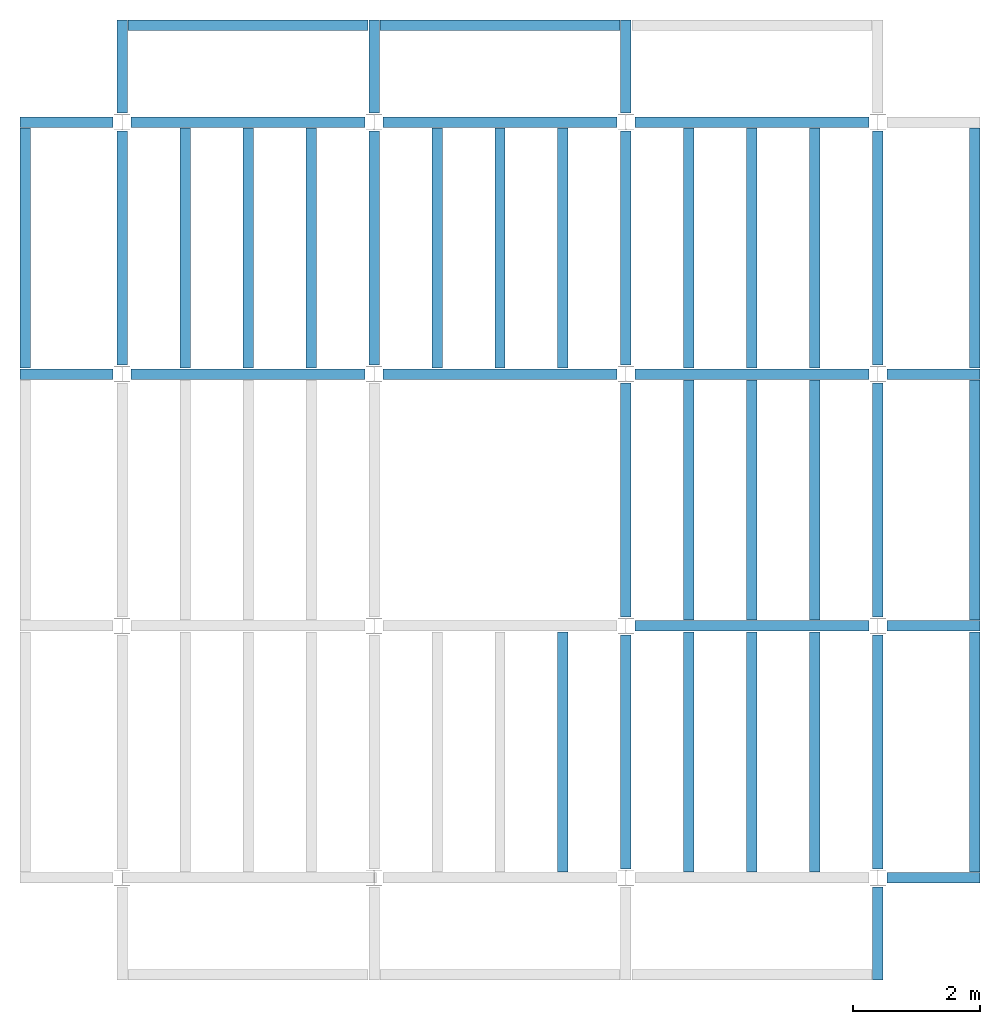
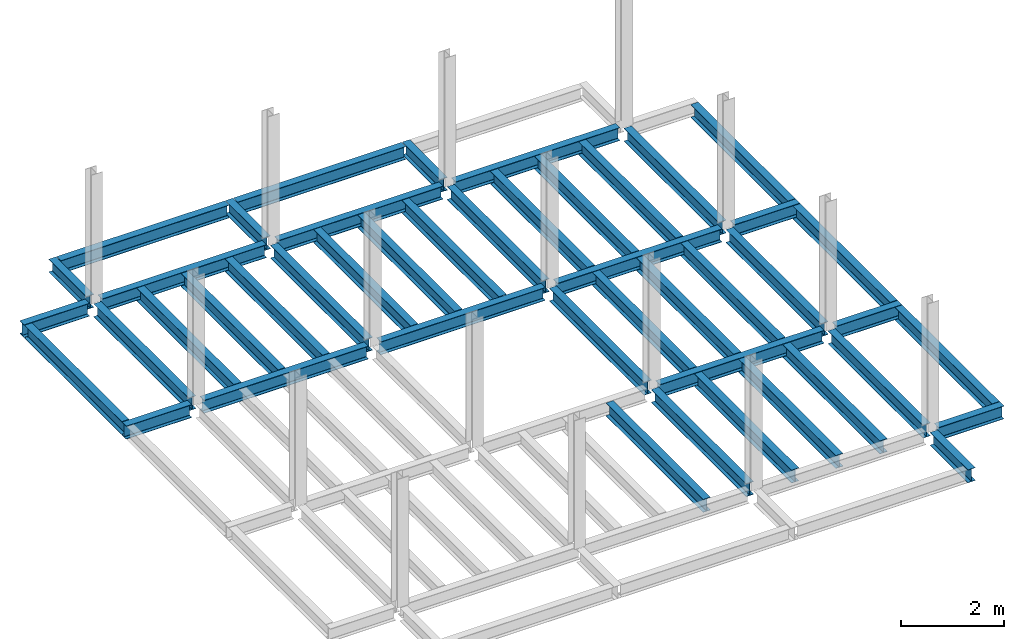
# One storey, part 2 of 3: 46 beams, 6 elements without a shape of their own.
"""IFC4 building model written with IfcOpenShell, lengths in feet."""

from ifc_helpers import new_model, entity, si_unit, converted_unit, derived_unit, direction, frame, origin, place, context, subcontext, project, spatial, line, arc, indexed_curve, outline, extrude, source, transform, mapped, material, type_object, type_shapes, element, aggregate, save


model = new_model("IFC4")

# Units and contexts
model_context = context("Model", 3, precision=0.0001, world=origin(), true_north=direction((6.123233995736766e-17, 1.0)))
plan_context = context("Plan", 3, precision=0.0001, world=origin(), true_north=direction((6.123233995736766e-17, 1.0)))
body_context = subcontext(model_context, "Body", "Model", "MODEL_VIEW")
ifc_project = project(units=[converted_unit("LENGTHUNIT", "FOOT", entity("IfcLengthMeasure", 0.3048), si_unit("LENGTHUNIT", "METRE"), dimensions=[1, 0, 0, 0, 0, 0, 0]), converted_unit("AREAUNIT", "SQUARE FOOT", entity("IfcAreaMeasure", 0.09290304), si_unit("AREAUNIT", "SQUARE_METRE"), dimensions=[2, 0, 0, 0, 0, 0, 0]), converted_unit("PLANEANGLEUNIT", "DEGREE", entity("IfcPlaneAngleMeasure", 0.017453292519943278), si_unit("PLANEANGLEUNIT", "RADIAN"), dimensions=[0, 0, 0, 0, 0, 0, 0]), converted_unit("VOLUMEUNIT", "CUBIC FOOT", entity("IfcVolumeMeasure", 0.028316846592000004), si_unit("VOLUMEUNIT", "CUBIC_METRE"), dimensions=[3, 0, 0, 0, 0, 0, 0]), si_unit("PRESSUREUNIT", "PASCAL"), derived_unit("MASSDENSITYUNIT", [(si_unit("MASSUNIT", "GRAM", prefix="KILO"), 1), (si_unit("LENGTHUNIT", "METRE"), -3)]), derived_unit("VAPORPERMEABILITYUNIT", [(si_unit("LENGTHUNIT", "METRE"), -1), (si_unit("TIMEUNIT", "SECOND"), 1)]), derived_unit("USERDEFINED", [(si_unit("MASSUNIT", "GRAM", prefix="KILO"), 1), (si_unit("LENGTHUNIT", "METRE"), 3), (si_unit("TIMEUNIT", "SECOND"), -3), (si_unit("ELECTRICCURRENTUNIT", "AMPERE"), -2)]), derived_unit("MODULUSOFELASTICITYUNIT", [(si_unit("MASSUNIT", "GRAM", prefix="KILO"), 1), (si_unit("LENGTHUNIT", "METRE"), -1), (si_unit("TIMEUNIT", "SECOND"), -2)]), derived_unit("THERMALEXPANSIONCOEFFICIENTUNIT", [(si_unit("THERMODYNAMICTEMPERATUREUNIT", "KELVIN"), -1)]), derived_unit("SPECIFICHEATCAPACITYUNIT", [(si_unit("TIMEUNIT", "SECOND"), -2), (si_unit("THERMODYNAMICTEMPERATUREUNIT", "KELVIN"), -1), (si_unit("LENGTHUNIT", "METRE"), 2)]), derived_unit("THERMALCONDUCTANCEUNIT", [(si_unit("MASSUNIT", "GRAM", prefix="KILO"), 1), (si_unit("TIMEUNIT", "SECOND"), -3), (si_unit("THERMODYNAMICTEMPERATUREUNIT", "KELVIN"), -1), (si_unit("LENGTHUNIT", "METRE"), 1)])], contexts=[model_context, plan_context])

# Site, building, storey
site_placement = place(None, origin())
site = spatial("IfcSite", under=ifc_project, at=site_placement, CompositionType="ELEMENT")
building_placement = place(site_placement, origin())
building = spatial("IfcBuilding", under=site, at=building_placement, CompositionType="ELEMENT")
storey_placement = place(building_placement, frame((0.0, 0.0, 59.875)))
storey = spatial("IfcBuildingStorey", under=building, at=storey_placement, Name="STR 07", CompositionType="ELEMENT", Elevation=59.875)

# Beams
ifc_material = material(Name="Steel ASTM A992", Category="Metal")
beam_type_1 = type_object("IfcBeamType", Name="W12X26", PredefinedType="JOIST", material=ifc_material)
shared_shape_1 = source(origin(), body_context, "Body", "SweptSolid", [
    extrude(outline(indexed_curve([(-0.27041666666666714, -0.47666666666666574), (-0.27041666666666714, -0.5083333333333351), (0.2704166666666669, -0.5083333333333351), (0.2704166666666669, -0.47666666666666574), (0.03458333333333309, -0.47666666666666574), (0.016905663803669493, -0.46934433619632937), (0.009583333333333202, -0.4516666666666659), (0.0095833333333332, 0.45166666666666705), (0.01690566380366948, 0.4693443361963307), (0.03458333333333325, 0.4766666666666671), (0.2704166666666669, 0.4766666666666671), (0.2704166666666669, 0.5083333333333312), (-0.2704166666666655, 0.5083333333333312), (-0.2704166666666655, 0.4766666666666671), (-0.034583333333333514, 0.47666666666666707), (-0.016905663803669865, 0.46934433619633054), (-0.009583333333333737, 0.45166666666666694), (-0.009583333333333735, -0.4516666666666658), (-0.01690566380367013, -0.4693443361963295), (-0.03458333333333368, -0.47666666666666574)], segments=[line(1, 2, 3, 4, 5), arc(5, 6, 7), line(7, 8), arc(8, 9, 10), line(10, 11, 12, 13, 14, 15), arc(15, 16, 17), line(17, 18), arc(18, 19, 20), line(20, 1)], self_intersect=False)), frame((-6.103346456692914, 0.0, 0.0), z_axis=(-1.0, 0.0, 0.0), x_axis=(0.0, -1.0, 0.0)), (0.0, 0.0, -1.0), 12.083333333333323),
])
type_shapes(beam_type_1, [shared_shape_1])
for number, where, name in (
    (1, (6.561679790026307, 39.0, -0.5083333333333329), "W12X26"),
    (2, (6.561679790026288, 26.0, -0.5083333333333329), "W12X26"),
):
    element("IfcBeam", number, at=place(storey_placement, frame(where)), inside=storey, type_object=beam_type_1, material=ifc_material, Name=name, ObjectType="W Shapes:W12X26", PredefinedType="JOIST", context=body_context, shape_type="MappedRepresentation", body=[
        mapped(shared_shape_1, transform((0.0, 0.0, 0.0), scale=1.0)),
    ])
for number, where, z_axis, x_axis, name in (
    (3, (39.0, 6.56167979002612, -0.5083333333333329), (0.0, 0.0, 1.0), (0.0, 1.0, 0.0), "W12X26"),
    (4, (26.0, 6.561679790026162, -0.5083333333333329), (0.0, 0.0, 1.0), (0.0, 1.0, 0.0), "W12X26"),
):
    element("IfcBeam", number, at=place(storey_placement, frame(where, z_axis=z_axis, x_axis=x_axis)), inside=storey, type_object=beam_type_1, material=ifc_material, Name=name, ObjectType="W Shapes:W12X26", PredefinedType="JOIST", context=body_context, shape_type="MappedRepresentation", body=[
        mapped(shared_shape_1, transform((0.0, 0.0, 0.0), scale=1.0)),
    ])
beam_type_2 = type_object("IfcBeamType", Name="W12X26", PredefinedType="JOIST", material=ifc_material)
shared_shape_2 = source(origin(), body_context, "Body", "SweptSolid", [
    extrude(outline(indexed_curve([(-0.27041666666666714, -0.47666666666666574), (-0.27041666666666714, -0.5083333333333351), (0.2704166666666669, -0.5083333333333351), (0.2704166666666669, -0.47666666666666574), (0.03458333333333309, -0.47666666666666574), (0.016905663803669493, -0.46934433619632937), (0.009583333333333202, -0.4516666666666659), (0.0095833333333332, 0.45166666666666705), (0.01690566380366948, 0.4693443361963307), (0.03458333333333325, 0.4766666666666671), (0.2704166666666669, 0.4766666666666671), (0.2704166666666669, 0.5083333333333312), (-0.2704166666666655, 0.5083333333333312), (-0.2704166666666655, 0.4766666666666671), (-0.034583333333333514, 0.47666666666666707), (-0.016905663803669865, 0.46934433619633054), (-0.009583333333333737, 0.45166666666666694), (-0.009583333333333735, -0.4516666666666658), (-0.01690566380367013, -0.4693443361963295), (-0.03458333333333368, -0.47666666666666574)], segments=[line(1, 2, 3, 4, 5), arc(5, 6, 7), line(7, 8), arc(8, 9, 10), line(10, 11, 12, 13, 14, 15), arc(15, 16, 17), line(17, 18), arc(18, 19, 20), line(20, 1)], self_intersect=False)), frame((-6.226706036745409, 0.0, 0.0), z_axis=(-1.0, 0.0, 0.0), x_axis=(0.0, -1.0, 0.0)), (0.0, 0.0, -1.0), 12.08333333333333),
])
type_shapes(beam_type_2, [shared_shape_2])
for number, where, name in (
    (5, (19.685039370078798, 39.0, -0.5083333333333329), "W12X26"),
    (6, (19.68503937007878, 26.0, -0.5083333333333329), "W12X26"),
):
    element("IfcBeam", number, at=place(storey_placement, frame(where)), inside=storey, type_object=beam_type_2, material=ifc_material, Name=name, ObjectType="W Shapes:W12X26", PredefinedType="JOIST", context=body_context, shape_type="MappedRepresentation", body=[
        mapped(shared_shape_2, transform((0.0, 0.0, 0.0), scale=1.0)),
    ])
for number, where, z_axis, x_axis, name in (
    (7, (39.0, 19.685039370078613, -0.5083333333333329), (0.0, 0.0, 1.0), (0.0, 1.0, 0.0), "W12X26"),
    (8, (26.0, 19.685039370078655, -0.5083333333333329), (0.0, 0.0, 1.0), (0.0, 1.0, 0.0), "W12X26"),
):
    element("IfcBeam", number, at=place(storey_placement, frame(where, z_axis=z_axis, x_axis=x_axis)), inside=storey, type_object=beam_type_2, material=ifc_material, Name=name, ObjectType="W Shapes:W12X26", PredefinedType="JOIST", context=body_context, shape_type="MappedRepresentation", body=[
        mapped(shared_shape_2, transform((0.0, 0.0, 0.0), scale=1.0)),
    ])

# Assembly, beams
assembly_1_placement = place(storey_placement, origin())
assembly_1 = element("IfcElementAssembly", 9, at=assembly_1_placement, inside=storey, Name="Structural Framing System", ObjectType="Structural Beam System:Structural Framing System", AssemblyPlace="NOTDEFINED", PredefinedType="BEAM_GRID")
beam_type_3 = type_object("IfcBeamType", Name="W12X26", PredefinedType="JOIST", material=ifc_material)
shared_shape_3 = source(origin(), body_context, "Body", "SweptSolid", [
    extrude(outline(indexed_curve([(-0.27041666666666714, -0.47666666666666574), (-0.27041666666666714, -0.5083333333333351), (0.2704166666666669, -0.5083333333333351), (0.2704166666666669, -0.47666666666666574), (0.03458333333333309, -0.47666666666666574), (0.016905663803669493, -0.46934433619632937), (0.009583333333333202, -0.4516666666666659), (0.0095833333333332, 0.45166666666666705), (0.01690566380366948, 0.4693443361963307), (0.03458333333333325, 0.4766666666666671), (0.2704166666666669, 0.4766666666666671), (0.2704166666666669, 0.5083333333333312), (-0.2704166666666655, 0.5083333333333312), (-0.2704166666666655, 0.4766666666666671), (-0.034583333333333514, 0.47666666666666707), (-0.016905663803669865, 0.46934433619633054), (-0.009583333333333737, 0.45166666666666694), (-0.009583333333333735, -0.4516666666666658), (-0.01690566380367013, -0.4693443361963295), (-0.03458333333333368, -0.47666666666666574)], segments=[line(1, 2, 3, 4, 5), arc(5, 6, 7), line(7, 8), arc(8, 9, 10), line(10, 11, 12, 13, 14, 15), arc(15, 16, 17), line(17, 18), arc(18, 19, 20), line(20, 1)], self_intersect=False)), frame((-6.187916666666566, 0.0, 0.0), z_axis=(-1.0, 0.0, 0.0), x_axis=(0.0, -1.0, 0.0)), (0.0, 0.0, -1.0), 12.375833333333075),
])
type_shapes(beam_type_3, [shared_shape_3])
beam_1_placement = place(assembly_1_placement, frame((3.250000000000073, 32.49999999999969, -0.5083333333333329), z_axis=(0.0, 0.0, 1.0), x_axis=(0.0, 1.0, 0.0)))
beam_1 = element("IfcBeam", 10, at=beam_1_placement, type_object=beam_type_3, material=ifc_material, Name="W12X26", ObjectType="W Shapes:W12X26", PredefinedType="JOIST", context=body_context, shape_type="MappedRepresentation", body=[
    mapped(shared_shape_3, transform((0.0, 0.0, 0.0), scale=1.0)),
])
beam_2_placement = place(assembly_1_placement, frame((6.500000000000094, 32.49999999999967, -0.5083333333333329), z_axis=(0.0, 0.0, 1.0), x_axis=(0.0, 1.0, 0.0)))
beam_2 = element("IfcBeam", 11, at=beam_2_placement, type_object=beam_type_3, material=ifc_material, Name="W12X26", ObjectType="W Shapes:W12X26", PredefinedType="JOIST", context=body_context, shape_type="MappedRepresentation", body=[
    mapped(shared_shape_3, transform((0.0, 0.0, 0.0), scale=1.0)),
])
beam_3_placement = place(assembly_1_placement, frame((9.750000000000115, 32.49999999999966, -0.5083333333333329), z_axis=(0.0, 0.0, 1.0), x_axis=(0.0, 1.0, 0.0)))
beam_3 = element("IfcBeam", 12, at=beam_3_placement, type_object=beam_type_3, material=ifc_material, Name="W12X26", ObjectType="W Shapes:W12X26", PredefinedType="JOIST", context=body_context, shape_type="MappedRepresentation", body=[
    mapped(shared_shape_3, transform((0.0, 0.0, 0.0), scale=1.0)),
])
aggregate(assembly_1, [beam_1, beam_2, beam_3])

# Assembly, beam
assembly_2_placement = place(storey_placement, origin())
assembly_2 = element("IfcElementAssembly", 13, at=assembly_2_placement, inside=storey, Name="Structural Framing System", ObjectType="Structural Beam System:Structural Framing System", AssemblyPlace="NOTDEFINED", PredefinedType="BEAM_GRID")
beam_4_placement = place(assembly_2_placement, frame((22.750000000000103, 6.499999999999801, -0.5083333333333329), z_axis=(0.0, 0.0, 1.0), x_axis=(0.0, 1.0, 0.0)))
beam_4 = element("IfcBeam", 14, at=beam_4_placement, type_object=beam_type_3, material=ifc_material, Name="W12X26", ObjectType="W Shapes:W12X26", PredefinedType="JOIST", context=body_context, shape_type="MappedRepresentation", body=[
    mapped(shared_shape_3, transform((0.0, 0.0, 0.0), scale=1.0)),
])
aggregate(assembly_2, [beam_4])

# Assembly, beams
assembly_3_placement = place(storey_placement, origin())
assembly_3 = element("IfcElementAssembly", 15, at=assembly_3_placement, inside=storey, Name="Structural Framing System", ObjectType="Structural Beam System:Structural Framing System", AssemblyPlace="NOTDEFINED", PredefinedType="BEAM_GRID")
beam_5_placement = place(assembly_3_placement, frame((16.25000000000014, 32.499999999999645, -0.5083333333333329), z_axis=(0.0, 0.0, 1.0), x_axis=(0.0, 1.0, 0.0)))
beam_5 = element("IfcBeam", 16, at=beam_5_placement, type_object=beam_type_3, material=ifc_material, Name="W12X26", ObjectType="W Shapes:W12X26", PredefinedType="JOIST", context=body_context, shape_type="MappedRepresentation", body=[
    mapped(shared_shape_3, transform((0.0, 0.0, 0.0), scale=1.0)),
])
beam_6_placement = place(assembly_3_placement, frame((19.50000000000014, 32.49999999999963, -0.5083333333333329), z_axis=(0.0, 0.0, 1.0), x_axis=(0.0, 1.0, 0.0)))
beam_6 = element("IfcBeam", 17, at=beam_6_placement, type_object=beam_type_3, material=ifc_material, Name="W12X26", ObjectType="W Shapes:W12X26", PredefinedType="JOIST", context=body_context, shape_type="MappedRepresentation", body=[
    mapped(shared_shape_3, transform((0.0, 0.0, 0.0), scale=1.0)),
])
beam_7_placement = place(assembly_3_placement, frame((22.750000000000142, 32.499999999999616, -0.5083333333333329), z_axis=(0.0, 0.0, 1.0), x_axis=(0.0, 1.0, 0.0)))
beam_7 = element("IfcBeam", 18, at=beam_7_placement, type_object=beam_type_3, material=ifc_material, Name="W12X26", ObjectType="W Shapes:W12X26", PredefinedType="JOIST", context=body_context, shape_type="MappedRepresentation", body=[
    mapped(shared_shape_3, transform((0.0, 0.0, 0.0), scale=1.0)),
])
aggregate(assembly_3, [beam_5, beam_6, beam_7])

assembly_4_placement = place(storey_placement, origin())
assembly_4 = element("IfcElementAssembly", 19, at=assembly_4_placement, inside=storey, Name="Structural Framing System", ObjectType="Structural Beam System:Structural Framing System", AssemblyPlace="NOTDEFINED", PredefinedType="BEAM_GRID")
beam_8_placement = place(assembly_4_placement, frame((29.2500000000001, 6.49999999999975, -0.5083333333333329), z_axis=(0.0, 0.0, 1.0), x_axis=(0.0, 1.0, 0.0)))
beam_8 = element("IfcBeam", 20, at=beam_8_placement, type_object=beam_type_3, material=ifc_material, Name="W12X26", ObjectType="W Shapes:W12X26", PredefinedType="JOIST", context=body_context, shape_type="MappedRepresentation", body=[
    mapped(shared_shape_3, transform((0.0, 0.0, 0.0), scale=1.0)),
])
beam_9_placement = place(assembly_4_placement, frame((32.5000000000001, 6.499999999999737, -0.5083333333333329), z_axis=(0.0, 0.0, 1.0), x_axis=(0.0, 1.0, 0.0)))
beam_9 = element("IfcBeam", 21, at=beam_9_placement, type_object=beam_type_3, material=ifc_material, Name="W12X26", ObjectType="W Shapes:W12X26", PredefinedType="JOIST", context=body_context, shape_type="MappedRepresentation", body=[
    mapped(shared_shape_3, transform((0.0, 0.0, 0.0), scale=1.0)),
])
beam_10_placement = place(assembly_4_placement, frame((35.7500000000001, 6.499999999999728, -0.5083333333333329), z_axis=(0.0, 0.0, 1.0), x_axis=(0.0, 1.0, 0.0)))
beam_10 = element("IfcBeam", 22, at=beam_10_placement, type_object=beam_type_3, material=ifc_material, Name="W12X26", ObjectType="W Shapes:W12X26", PredefinedType="JOIST", context=body_context, shape_type="MappedRepresentation", body=[
    mapped(shared_shape_3, transform((0.0, 0.0, 0.0), scale=1.0)),
])
aggregate(assembly_4, [beam_8, beam_9, beam_10])

assembly_5_placement = place(storey_placement, origin())
assembly_5 = element("IfcElementAssembly", 23, at=assembly_5_placement, inside=storey, Name="Structural Framing System", ObjectType="Structural Beam System:Structural Framing System", AssemblyPlace="NOTDEFINED", PredefinedType="BEAM_GRID")
beam_11_placement = place(assembly_5_placement, frame((29.25000000000012, 19.499999999999595, -0.5083333333333329), z_axis=(0.0, 0.0, 1.0), x_axis=(0.0, 1.0, 0.0)))
beam_11 = element("IfcBeam", 24, at=beam_11_placement, type_object=beam_type_3, material=ifc_material, Name="W12X26", ObjectType="W Shapes:W12X26", PredefinedType="JOIST", context=body_context, shape_type="MappedRepresentation", body=[
    mapped(shared_shape_3, transform((0.0, 0.0, 0.0), scale=1.0)),
])
beam_12_placement = place(assembly_5_placement, frame((32.500000000000114, 19.49999999999958, -0.5083333333333329), z_axis=(0.0, 0.0, 1.0), x_axis=(0.0, 1.0, 0.0)))
beam_12 = element("IfcBeam", 25, at=beam_12_placement, type_object=beam_type_3, material=ifc_material, Name="W12X26", ObjectType="W Shapes:W12X26", PredefinedType="JOIST", context=body_context, shape_type="MappedRepresentation", body=[
    mapped(shared_shape_3, transform((0.0, 0.0, 0.0), scale=1.0)),
])
beam_13_placement = place(assembly_5_placement, frame((35.750000000000114, 19.499999999999574, -0.5083333333333329), z_axis=(0.0, 0.0, 1.0), x_axis=(0.0, 1.0, 0.0)))
beam_13 = element("IfcBeam", 26, at=beam_13_placement, type_object=beam_type_3, material=ifc_material, Name="W12X26", ObjectType="W Shapes:W12X26", PredefinedType="JOIST", context=body_context, shape_type="MappedRepresentation", body=[
    mapped(shared_shape_3, transform((0.0, 0.0, 0.0), scale=1.0)),
])
aggregate(assembly_5, [beam_11, beam_12, beam_13])

assembly_6_placement = place(storey_placement, origin())
assembly_6 = element("IfcElementAssembly", 27, at=assembly_6_placement, inside=storey, Name="Structural Framing System", ObjectType="Structural Beam System:Structural Framing System", AssemblyPlace="NOTDEFINED", PredefinedType="BEAM_GRID")
beam_14_placement = place(assembly_6_placement, frame((29.250000000000142, 32.4999999999996, -0.5083333333333329), z_axis=(0.0, 0.0, 1.0), x_axis=(0.0, 1.0, 0.0)))
beam_14 = element("IfcBeam", 28, at=beam_14_placement, type_object=beam_type_3, material=ifc_material, Name="W12X26", ObjectType="W Shapes:W12X26", PredefinedType="JOIST", context=body_context, shape_type="MappedRepresentation", body=[
    mapped(shared_shape_3, transform((0.0, 0.0, 0.0), scale=1.0)),
])
beam_15_placement = place(assembly_6_placement, frame((32.50000000000014, 32.49999999999959, -0.5083333333333329), z_axis=(0.0, 0.0, 1.0), x_axis=(0.0, 1.0, 0.0)))
beam_15 = element("IfcBeam", 29, at=beam_15_placement, type_object=beam_type_3, material=ifc_material, Name="W12X26", ObjectType="W Shapes:W12X26", PredefinedType="JOIST", context=body_context, shape_type="MappedRepresentation", body=[
    mapped(shared_shape_3, transform((0.0, 0.0, 0.0), scale=1.0)),
])
beam_16_placement = place(assembly_6_placement, frame((35.75000000000014, 32.499999999999574, -0.5083333333333329), z_axis=(0.0, 0.0, 1.0), x_axis=(0.0, 1.0, 0.0)))
beam_16 = element("IfcBeam", 30, at=beam_16_placement, type_object=beam_type_3, material=ifc_material, Name="W12X26", ObjectType="W Shapes:W12X26", PredefinedType="JOIST", context=body_context, shape_type="MappedRepresentation", body=[
    mapped(shared_shape_3, transform((0.0, 0.0, 0.0), scale=1.0)),
])
aggregate(assembly_6, [beam_14, beam_15, beam_16])

# Beams
for number, where, z_axis, x_axis, name in (
    (31, (-5.0, 32.4999999999997, -0.5083333333333329), (0.0, 0.0, 1.0), (0.0, 1.0, 0.0), "W12X26"),
    (32, (44.0, 6.4999999999997, -0.5083333333333329), (0.0, 0.0, 1.0), (0.0, 1.0, 0.0), "W12X26"),
    (33, (44.0, 19.499999999999545, -0.5083333333333329), (0.0, 0.0, 1.0), (0.0, 1.0, 0.0), "W12X26"),
    (34, (44.0, 32.499999999999545, -0.5083333333333329), (0.0, 0.0, 1.0), (0.0, 1.0, 0.0), "W12X26"),
):
    element("IfcBeam", number, at=place(storey_placement, frame(where, z_axis=z_axis, x_axis=x_axis)), inside=storey, type_object=beam_type_3, material=ifc_material, Name=name, ObjectType="W Shapes:W12X26", PredefinedType="JOIST", context=body_context, shape_type="MappedRepresentation", body=[
        mapped(shared_shape_3, transform((0.0, 0.0, 0.0), scale=1.0)),
    ])
beam_17_placement = place(storey_placement, frame((6.5000000000001625, 44.0, -0.5083333333333329)))
element("IfcBeam", 35, at=beam_17_placement, inside=storey, type_object=beam_type_3, material=ifc_material, Name="W Shapes:W12X26", ObjectType="W Shapes:W12X26", PredefinedType="JOIST", context=body_context, shape_type="MappedRepresentation", body=[
    mapped(shared_shape_3, transform((0.0, 0.0, 0.0), scale=1.0)),
])
beam_type_4 = type_object("IfcBeamType", Name="W12X26", PredefinedType="JOIST", material=ifc_material)
shared_shape_4 = source(origin(), body_context, "Body", "SweptSolid", [
    extrude(outline(indexed_curve([(-0.27041666666666714, -0.47666666666666574), (-0.27041666666666714, -0.5083333333333351), (0.2704166666666669, -0.5083333333333351), (0.2704166666666669, -0.47666666666666574), (0.03458333333333309, -0.47666666666666574), (0.016905663803669493, -0.46934433619632937), (0.009583333333333202, -0.4516666666666659), (0.0095833333333332, 0.45166666666666705), (0.01690566380366948, 0.4693443361963307), (0.03458333333333325, 0.4766666666666671), (0.2704166666666669, 0.4766666666666671), (0.2704166666666669, 0.5083333333333312), (-0.2704166666666655, 0.5083333333333312), (-0.2704166666666655, 0.4766666666666671), (-0.034583333333333514, 0.47666666666666707), (-0.016905663803669865, 0.46934433619633054), (-0.009583333333333737, 0.45166666666666694), (-0.009583333333333735, -0.4516666666666658), (-0.01690566380367013, -0.4693443361963295), (-0.03458333333333368, -0.47666666666666574)], segments=[line(1, 2, 3, 4, 5), arc(5, 6, 7), line(7, 8), arc(8, 9, 10), line(10, 11, 12, 13, 14, 15), arc(15, 16, 17), line(17, 18), arc(18, 19, 20), line(20, 1)], self_intersect=False)), frame((-6.165026246719308, 0.0, 0.0), z_axis=(-1.0, 0.0, 0.0), x_axis=(0.0, -1.0, 0.0)), (0.0, 0.0, -1.0), 12.08333333333334),
])
type_shapes(beam_type_4, [shared_shape_4])
for number, where, name in (
    (36, (32.6233595800526, 39.0, -0.5083333333333329), "W12X26"),
    (37, (32.62335958005258, 26.0, -0.5083333333333329), "W12X26"),
    (38, (32.62335958005255, 13.0, -0.5083333333333329), "W12X26"),
):
    element("IfcBeam", number, at=place(storey_placement, frame(where)), inside=storey, type_object=beam_type_4, material=ifc_material, Name=name, ObjectType="W Shapes:W12X26", PredefinedType="JOIST", context=body_context, shape_type="MappedRepresentation", body=[
        mapped(shared_shape_4, transform((0.0, 0.0, 0.0), scale=1.0)),
    ])
for number, where, z_axis, x_axis, name in (
    (39, (39.0, 32.62335958005221, -0.5083333333333329), (0.0, 0.0, 1.0), (0.0, 1.0, 0.0), "W12X26"),
    (40, (26.0, 32.62335958005225, -0.5083333333333329), (0.0, 0.0, 1.0), (0.0, 1.0, 0.0), "W12X26"),
    (41, (13.0, 32.623359580052295, -0.5083333333333329), (0.0, 0.0, 1.0), (0.0, 1.0, 0.0), "W12X26"),
    (42, (0.0, 32.62335958005234, -0.5083333333333329), (0.0, 0.0, 1.0), (0.0, 1.0, 0.0), "W12X26"),
):
    element("IfcBeam", number, at=place(storey_placement, frame(where, z_axis=z_axis, x_axis=x_axis)), inside=storey, type_object=beam_type_4, material=ifc_material, Name=name, ObjectType="W Shapes:W12X26", PredefinedType="JOIST", context=body_context, shape_type="MappedRepresentation", body=[
        mapped(shared_shape_4, transform((0.0, 0.0, 0.0), scale=1.0)),
    ])
beam_type_5 = type_object("IfcBeamType", Name="W12X26", PredefinedType="JOIST", material=ifc_material)
shared_shape_5 = source(origin(), body_context, "Body", "SweptSolid", [
    extrude(outline(indexed_curve([(0.47666666666666574, -0.2704166666666672), (0.5083333333333351, -0.2704166666666672), (0.5083333333333351, 0.27041666666666686), (0.47666666666666574, 0.27041666666666686), (0.47666666666666574, 0.03458333333333307), (0.46934433619632937, 0.016905663803669473), (0.4516666666666659, 0.00958333333333318), (-0.45166666666666705, 0.00958333333333318), (-0.4693443361963307, 0.01690566380366946), (-0.4766666666666671, 0.03458333333333323), (-0.4766666666666671, 0.27041666666666686), (-0.5083333333333312, 0.27041666666666686), (-0.5083333333333312, -0.27041666666666553), (-0.4766666666666671, -0.27041666666666553), (-0.47666666666666707, -0.034583333333333535), (-0.46934433619633054, -0.016905663803669885), (-0.45166666666666694, -0.00958333333333376), (0.4516666666666658, -0.009583333333333756), (0.4693443361963295, -0.01690566380367015), (0.47666666666666574, -0.0345833333333337)], segments=[line(1, 2, 3, 4, 5), arc(5, 6, 7), line(7, 8), arc(8, 9, 10), line(10, 11, 12, 13, 14, 15), arc(15, 16, 17), line(17, 18), arc(18, 19, 20), line(20, 1)], self_intersect=False)), frame((-2.0416666666666208, 0.0, 0.0), z_axis=(1.0, 0.0, 0.0), x_axis=(0.0, 0.0, -1.0)), (0.0, 0.0, 1.0), 4.812083333333336),
])
type_shapes(beam_type_5, [shared_shape_5])
for number, where, z_axis, x_axis, name in (
    (43, (-2.4999999999998104, 39.0, -0.5083333333333329), (0.0, 0.0, 1.0), (-1.0, 0.0, 0.0), "W12X26"),
    (44, (39.0, -2.50000000000058, -0.5083333333333329), (0.0, 0.0, 1.0), (0.0, -1.0, 0.0), "W12X26"),
    (45, (-2.4999999999998317, 26.0, -0.5083333333333329), (0.0, 0.0, 1.0), (-1.0, 0.0, 0.0), "W12X26"),
):
    element("IfcBeam", number, at=place(storey_placement, frame(where, z_axis=z_axis, x_axis=x_axis)), inside=storey, type_object=beam_type_5, material=ifc_material, Name=name, ObjectType="W Shapes:W12X26", PredefinedType="JOIST", context=body_context, shape_type="MappedRepresentation", body=[
        mapped(shared_shape_5, transform((0.0, 0.0, 0.0), scale=1.0)),
    ])
beam_type_6 = type_object("IfcBeamType", Name="W12X26", PredefinedType="JOIST", material=ifc_material)
shared_shape_6 = source(origin(), body_context, "Body", "SweptSolid", [
    extrude(outline(indexed_curve([(0.47666666666666574, -0.2704166666666672), (0.5083333333333351, -0.2704166666666672), (0.5083333333333351, 0.27041666666666686), (0.47666666666666574, 0.27041666666666686), (0.47666666666666574, 0.03458333333333307), (0.46934433619632937, 0.016905663803669473), (0.4516666666666659, 0.00958333333333318), (-0.45166666666666705, 0.00958333333333318), (-0.4693443361963307, 0.01690566380366946), (-0.4766666666666671, 0.03458333333333323), (-0.4766666666666671, 0.27041666666666686), (-0.5083333333333312, 0.27041666666666686), (-0.5083333333333312, -0.27041666666666553), (-0.4766666666666671, -0.27041666666666553), (-0.47666666666666707, -0.034583333333333535), (-0.46934433619633054, -0.016905663803669885), (-0.45166666666666694, -0.00958333333333376), (0.4516666666666658, -0.009583333333333756), (0.4693443361963295, -0.01690566380367015), (0.47666666666666574, -0.0345833333333337)], segments=[line(1, 2, 3, 4, 5), arc(5, 6, 7), line(7, 8), arc(8, 9, 10), line(10, 11, 12, 13, 14, 15), arc(15, 16, 17), line(17, 18), arc(18, 19, 20), line(20, 1)], self_intersect=False)), frame((-2.77041666666672, 0.0, 0.0), z_axis=(1.0, 0.0, 0.0), x_axis=(0.0, 0.0, -1.0)), (0.0, 0.0, 1.0), 4.812083333333389),
])
type_shapes(beam_type_6, [shared_shape_6])
for number, where, z_axis, x_axis, name in (
    (46, (41.50000000000013, 26.0, -0.5083333333333329), (0.0, 0.0, 1.0), (-1.0, 0.0, 0.0), "W12X26"),
    (47, (41.50000000000011, 13.0, -0.5083333333333329), (0.0, 0.0, 1.0), (-1.0, 0.0, 0.0), "W12X26"),
    (48, (41.500000000000085, 0.0, -0.5083333333333329), (0.0, 0.0, 1.0), (-1.0, 0.0, 0.0), "W12X26"),
    (49, (13.0, 41.49999999999965, -0.5083333333333329), (0.0, 0.0, 1.0), (0.0, -1.0, 0.0), "W12X26"),
    (50, (0.0, 41.499999999999694, -0.5083333333333329), (0.0, 0.0, 1.0), (0.0, -1.0, 0.0), "W12X26"),
):
    element("IfcBeam", number, at=place(storey_placement, frame(where, z_axis=z_axis, x_axis=x_axis)), inside=storey, type_object=beam_type_6, material=ifc_material, Name=name, ObjectType="W Shapes:W12X26", PredefinedType="JOIST", context=body_context, shape_type="MappedRepresentation", body=[
        mapped(shared_shape_6, transform((0.0, 0.0, 0.0), scale=1.0)),
    ])
beam_type_7 = type_object("IfcBeamType", Name="W12X26", PredefinedType="JOIST", material=ifc_material)
shared_shape_7 = source(origin(), body_context, "Body", "SweptSolid", [
    extrude(outline(indexed_curve([(-0.2704166666666694, -0.5083333333333329), (0.27041666666666586, -0.5083333333333329), (0.2704166666666623, -0.47666666666666657), (0.034583333333333854, -0.47666666666666657), (0.016905663803669313, -0.469344336196329), (0.009583333333335275, -0.451666666666668), (0.009583333333335275, 0.451666666666668), (0.016905663803669313, 0.469344336196329), (0.034583333333333854, 0.47666666666666657), (0.2704166666666694, 0.4766666666666737), (0.27041666666666586, 0.50833333333334), (-0.27041666666666586, 0.5083333333333329), (-0.27041666666666586, 0.47666666666666657), (-0.0345833333333303, 0.47666666666666657), (-0.01690566380366576, 0.469344336196329), (-0.009583333333331723, 0.451666666666668), (-0.009583333333331723, -0.451666666666668), (-0.01690566380366576, -0.469344336196329), (-0.034583333333333854, -0.47666666666666657), (-0.27041666666666586, -0.47666666666666657)], segments=[line(1, 2, 3, 4), arc(4, 5, 6), line(6, 7), arc(7, 8, 9), line(9, 10, 11, 12, 13, 14), arc(14, 15, 16), line(16, 17), arc(17, 18, 19), line(19, 20, 1)], self_intersect=False)), frame((26.0, 44.27041666666632, 59.36666666666665), z_axis=(0.0, -1.0, 0.0), x_axis=(-1.0, 0.0, 0.0)), (0.0, 0.0, 1.0), 4.812083333333393),
])
type_shapes(beam_type_7, [shared_shape_7])
beam_18_placement = place(storey_placement, frame((0.0, 0.0, -59.875)))
element("IfcBeam", 51, at=beam_18_placement, inside=storey, type_object=beam_type_7, material=ifc_material, Name="W12X26", ObjectType="W Shapes:W12X26", PredefinedType="JOIST", context=body_context, shape_type="MappedRepresentation", body=[
    mapped(shared_shape_7, transform((0.0, 0.0, 0.0), scale=1.0)),
])
beam_type_8 = type_object("IfcBeamType", Name="W12X26", PredefinedType="JOIST", material=ifc_material)
shared_shape_8 = source(origin(), body_context, "Body", "SweptSolid", [
    extrude(outline(indexed_curve([(0.47666666666666574, -0.2704166666666672), (0.5083333333333351, -0.2704166666666672), (0.5083333333333351, 0.27041666666666686), (0.47666666666666574, 0.27041666666666686), (0.47666666666666574, 0.03458333333333307), (0.46934433619632937, 0.016905663803669473), (0.4516666666666659, 0.00958333333333318), (-0.45166666666666705, 0.00958333333333318), (-0.4693443361963307, 0.01690566380366946), (-0.4766666666666671, 0.03458333333333323), (-0.4766666666666671, 0.27041666666666686), (-0.5083333333333312, 0.27041666666666686), (-0.5083333333333312, -0.27041666666666553), (-0.4766666666666671, -0.27041666666666553), (-0.47666666666666707, -0.034583333333333535), (-0.46934433619633054, -0.016905663803669885), (-0.45166666666666694, -0.00958333333333376), (0.4516666666666658, -0.009583333333333756), (0.4693443361963295, -0.01690566380367015), (0.47666666666666574, -0.0345833333333337)], segments=[line(1, 2, 3, 4, 5), arc(5, 6, 7), line(7, 8), arc(8, 9, 10), line(10, 11, 12, 13, 14, 15), arc(15, 16, 17), line(17, 18), arc(18, 19, 20), line(20, 1)], self_intersect=False)), frame((-6.187916666666685, 0.0, 0.0), z_axis=(1.0, 0.0, 0.0), x_axis=(0.0, 0.0, -1.0)), (0.0, 0.0, 1.0), 12.375833333333318),
])
type_shapes(beam_type_8, [shared_shape_8])
beam_19_placement = place(storey_placement, frame((19.500000000000142, 44.0, -0.5083333333333329), z_axis=(0.0, 0.0, 1.0), x_axis=(-1.0, 0.0, 0.0)))
element("IfcBeam", 52, at=beam_19_placement, inside=storey, type_object=beam_type_8, material=ifc_material, Name="W Shapes:W12X26", ObjectType="W Shapes:W12X26", PredefinedType="JOIST", context=body_context, shape_type="MappedRepresentation", body=[
    mapped(shared_shape_8, transform((0.0, 0.0, 0.0), scale=1.0)),
])

save(model, "model.ifc")
